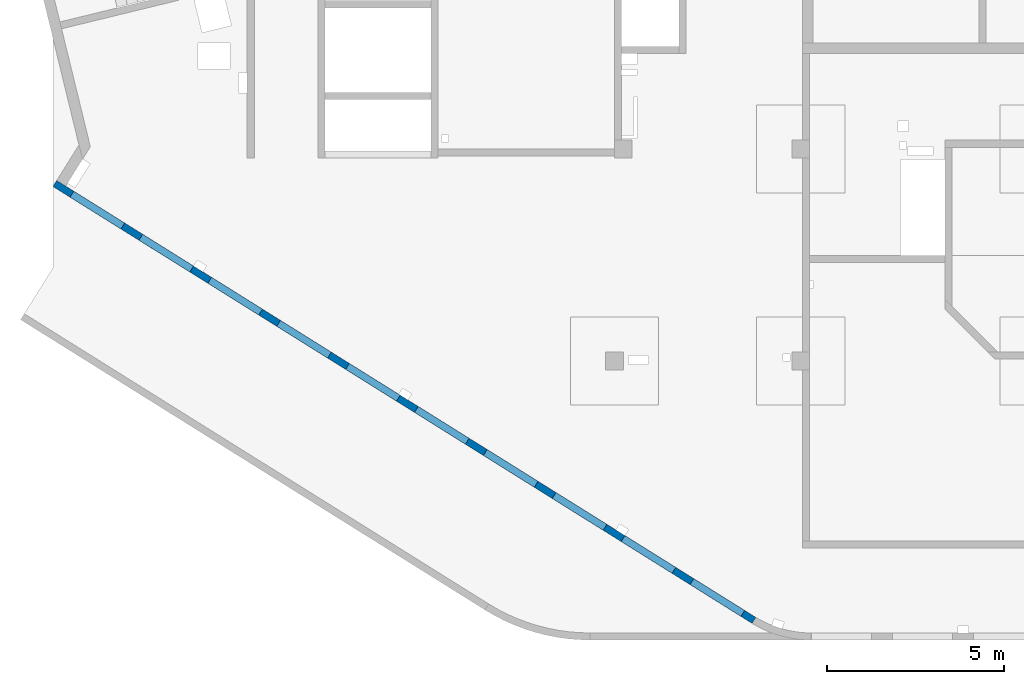
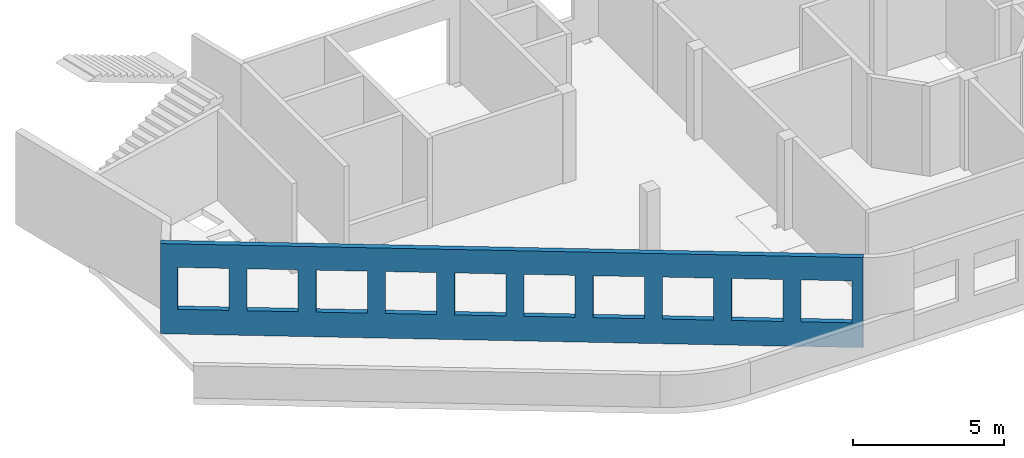
# One storey, part 7 of 10: 1 wall, 10 openings.
"""IFC4 building model written with IfcOpenShell, lengths in millimetres."""

from ifc_helpers import new_model, entity, si_unit, converted_unit, derived_unit, direction, frame, origin, place, context, subcontext, project, spatial, indexed_curve, outline, extrude, polygons, material, type_object, element, save


model = new_model("IFC4")

# Units and contexts
model_context = context("Model", 3, precision=0.01, world=origin(), true_north=direction((6.12303176911189e-17, 1.0)))
plan_context = context("Plan", 3, precision=0.01, world=origin(), true_north=direction((6.12303176911189e-17, 1.0)))
body_context = subcontext(model_context, "Body", "Model", "MODEL_VIEW")
ifc_project = project(units=[si_unit("LENGTHUNIT", "METRE", prefix="MILLI"), si_unit("AREAUNIT", "SQUARE_METRE"), si_unit("VOLUMEUNIT", "CUBIC_METRE"), converted_unit("PLANEANGLEUNIT", "DEGREE", entity("IfcRatioMeasure", 0.0174532925199433), si_unit("PLANEANGLEUNIT", "RADIAN"), dimensions=[0, 0, 0, 0, 0, 0, 0]), si_unit("MASSUNIT", "GRAM", prefix="KILO"), derived_unit("MASSDENSITYUNIT", [(si_unit("MASSUNIT", "GRAM", prefix="KILO"), 1), (si_unit("LENGTHUNIT", "METRE"), -3)]), derived_unit("MOMENTOFINERTIAUNIT", [(si_unit("LENGTHUNIT", "METRE"), 4)]), si_unit("TIMEUNIT", "SECOND"), si_unit("FREQUENCYUNIT", "HERTZ"), si_unit("THERMODYNAMICTEMPERATUREUNIT", "DEGREE_CELSIUS"), derived_unit("THERMALTRANSMITTANCEUNIT", [(si_unit("MASSUNIT", "GRAM", prefix="KILO"), 1), (si_unit("THERMODYNAMICTEMPERATUREUNIT", "KELVIN"), -1), (si_unit("TIMEUNIT", "SECOND"), -3)]), derived_unit("VOLUMETRICFLOWRATEUNIT", [(si_unit("LENGTHUNIT", "METRE"), 3), (si_unit("TIMEUNIT", "SECOND"), -1)]), derived_unit("MASSFLOWRATEUNIT", [(si_unit("MASSUNIT", "GRAM", prefix="KILO"), 1), (si_unit("TIMEUNIT", "SECOND"), -1)]), derived_unit("ROTATIONALFREQUENCYUNIT", [(si_unit("TIMEUNIT", "SECOND"), -1)]), si_unit("ELECTRICCURRENTUNIT", "AMPERE"), si_unit("ELECTRICVOLTAGEUNIT", "VOLT"), si_unit("POWERUNIT", "WATT"), si_unit("FORCEUNIT", "NEWTON", prefix="KILO"), si_unit("ILLUMINANCEUNIT", "LUX"), si_unit("LUMINOUSFLUXUNIT", "LUMEN"), si_unit("LUMINOUSINTENSITYUNIT", "CANDELA"), derived_unit("USERDEFINED", [(si_unit("MASSUNIT", "GRAM", prefix="KILO"), -1), (si_unit("LENGTHUNIT", "METRE"), -2), (si_unit("TIMEUNIT", "SECOND"), 3), (si_unit("LUMINOUSFLUXUNIT", "LUMEN"), 1)]), derived_unit("LINEARVELOCITYUNIT", [(si_unit("LENGTHUNIT", "METRE"), 1), (si_unit("TIMEUNIT", "SECOND"), -1)]), si_unit("PRESSUREUNIT", "PASCAL"), derived_unit("USERDEFINED", [(si_unit("LENGTHUNIT", "METRE"), -2), (si_unit("MASSUNIT", "GRAM", prefix="KILO"), 1), (si_unit("TIMEUNIT", "SECOND"), -2)]), derived_unit("LINEARFORCEUNIT", [(si_unit("MASSUNIT", "GRAM", prefix="KILO"), 1), (si_unit("LENGTHUNIT", "METRE"), 1), (si_unit("TIMEUNIT", "SECOND"), -2), (si_unit("LENGTHUNIT", "METRE"), -1)]), derived_unit("PLANARFORCEUNIT", [(si_unit("MASSUNIT", "GRAM", prefix="KILO"), 1), (si_unit("LENGTHUNIT", "METRE"), 1), (si_unit("TIMEUNIT", "SECOND"), -2), (si_unit("LENGTHUNIT", "METRE"), -2)])], contexts=[model_context, plan_context])

# Site, building, storey
site_placement = place(None, origin())
site = spatial("IfcSite", under=ifc_project, at=site_placement, CompositionType="ELEMENT")
building_placement = place(site_placement, origin())
building = spatial("IfcBuilding", under=site, at=building_placement, CompositionType="ELEMENT")
storey_placement = place(building_placement, frame((0.0, 0.0, 4200.0)))
storey = spatial("IfcBuildingStorey", under=building, at=storey_placement, Name="02", CompositionType="ELEMENT", Elevation=4200.0)

# Wall, openings
ifc_material = material()
wall_type = type_object("IfcWallType", Name=":ADSK_ 25_200", PredefinedType="STANDARD")
wall_placement = place(storey_placement, frame((19848.26, 354.97, -150.0), z_axis=(0.0, 0.0, 1.0), x_axis=(-0.848052743777572, 0.529911826412028, 0.0)))
wall = element("IfcWall", 1, at=wall_placement, inside=storey, type_object=wall_type, material=ifc_material, Name=":ADSK_ 25_200", ObjectType=":ADSK_ 25_200", PredefinedType="NOTDEFINED", context=body_context, shape_type="Tessellation", body=[
    polygons([(372.190668142856, -100.000000000002, 2700.0), (2072.19066814286, -99.9999999999992, 2700.0), (2072.19066814286, -99.9999999999992, 1000.00000000001), (372.190668142856, -100.000000000002, 1000.00000000001), (2672.19066814286, -99.9999999999992, 2700.0), (4372.19066814286, -99.9999999999973, 2700.0), (4372.19066814286, -99.9999999999973, 1000.00000000001), (2672.19066814286, -99.9999999999992, 1000.00000000001), (4972.19066814287, -99.9999999999968, 2700.0), (6672.19066814287, -99.9999999999946, 2700.0), (6672.19066814287, -99.9999999999946, 1000.00000000001), (4972.19066814287, -99.9999999999968, 1000.00000000001), (7272.19066814288, -99.9999999999935, 2700.0), (8972.19066814288, -99.9999999999924, 2700.0), (8972.19066814288, -99.9999999999924, 1000.00000000001), (7272.19066814288, -99.9999999999935, 1000.00000000001), (9572.19066814288, -99.9999999999913, 2700.0), (11272.1906681429, -99.9999999999913, 2700.0), (11272.1906681429, -99.9999999999913, 1000.00000000001), (9572.19066814288, -99.9999999999913, 1000.00000000001), (11872.1906681429, -99.9999999999892, 2700.0), (13572.1906681429, -99.9999999999881, 2700.0), (13572.1906681429, -99.9999999999881, 1000.00000000001), (11872.1906681429, -99.9999999999892, 1000.00000000001), (14172.1906681429, -99.9999999999859, 2700.0), (15872.1906681429, -99.9999999999859, 2700.0), (15872.1906681429, -99.9999999999859, 1000.00000000001), (14172.1906681429, -99.9999999999859, 1000.00000000001), (16472.1906681429, -99.9999999999849, 2700.0), (18172.1906681429, -99.9999999999827, 2700.0), (18172.1906681429, -99.9999999999827, 1000.00000000001), (16472.1906681429, -99.9999999999849, 1000.00000000001), (18772.1906681429, -99.9999999999827, 2700.0), (20472.1906681429, -99.9999999999794, 2700.0), (20472.1906681429, -99.9999999999794, 1000.00000000001), (18772.1906681429, -99.9999999999827, 1000.00000000001), (21072.1906681429, -99.9999999999794, 2700.0), (22772.1906681429, -99.9999999999773, 2700.0), (22772.1906681429, -99.9999999999773, 1000.00000000001), (21072.1906681429, -99.9999999999794, 1000.00000000001), (0.970164127873786, -99.9999999999997, 5.41433564649196e-13), (23041.7760623233, -99.9999999999989, 5.41433564649196e-13), (23341.7760623233, -100.000000000001, 5.41433564649196e-13), (23341.7760623233, -99.9999999999989, 3650.0), (23041.7760623233, -99.9999999999989, 3650.0), (18772.1906681429, -100.0, 3650.0), (18472.188348855, -99.9999999999978, 3650.0), (14002.1883486828, -100.0, 3650.0), (13802.1857175861, -99.9999999999989, 3650.0), (4972.1865942764, -99.9999999999995, 3650.0), (4672.18834832425, -99.9999999999995, 3650.0), (297.188348155941, -99.9999999999986, 3650.0), (97.1857170592183, -99.9999999999997, 3650.0), (0.97016412787338, -99.999999999999, 3650.0), (3.14708259452345e-12, 100.000000000001, 5.41433564649196e-13), (-6.42952358020921e-13, 99.9999999999993, 3650.0), (23341.7760623233, 99.9999999999989, 3650.0), (23341.7760623233, 99.9999999999989, 5.41433564649196e-13), (2072.19066814285, 100.000000000319, 2700.0), (372.190668142856, 100.000000000318, 2700.0), (372.190668142856, 100.000000000318, 1000.00000000001), (2072.19066814285, 100.00000000032, 1000.00000000001), (4372.19066814286, 100.000000000324, 2700.0), (2672.19066814286, 100.00000000032, 2700.0), (2672.19066814286, 100.00000000032, 1000.00000000001), (4372.19066814286, 100.000000000324, 1000.00000000001), (6672.19066814287, 100.000000000325, 2700.0), (4972.19066814287, 100.000000000323, 2700.0), (4972.19066814287, 100.000000000323, 1000.00000000001), (6672.19066814287, 100.000000000325, 1000.00000000001), (8972.19066814287, 100.000000000329, 2700.0), (7272.19066814287, 100.000000000325, 2700.0), (7272.19066814287, 100.000000000325, 1000.00000000001), (8972.19066814287, 100.000000000329, 1000.00000000001), (11272.1906681429, 100.000000000329, 2700.0), (9572.19066814288, 100.000000000327, 2700.0), (9572.19066814288, 100.000000000327, 1000.00000000001), (11272.1906681429, 100.000000000329, 1000.00000000001), (13572.1906681429, 100.000000000332, 2700.0), (11872.1906681429, 100.000000000331, 2700.0), (11872.1906681429, 100.000000000331, 1000.00000000001), (13572.1906681429, 100.000000000332, 1000.00000000001), (15872.1906681429, 100.000000000336, 2700.0), (14172.1906681429, 100.000000000334, 2700.0), (14172.1906681429, 100.000000000334, 1000.00000000001), (15872.1906681429, 100.000000000336, 1000.00000000001), (18172.1906681429, 100.000000000337, 2700.0), (16472.1906681429, 100.000000000336, 2700.0), (16472.1906681429, 100.000000000336, 1000.00000000001), (18172.1906681429, 100.000000000337, 1000.00000000001), (20472.1906681429, 100.000000000339, 2700.0), (18772.1906681429, 100.000000000337, 2700.0), (18772.1906681429, 100.000000000338, 1000.00000000001), (20472.1906681429, 100.000000000338, 1000.00000000001), (22772.1906681429, 100.000000000343, 2700.0), (21072.1906681429, 100.00000000034, 2700.0), (21072.1906681429, 100.00000000034, 1000.00000000001), (22772.1906681429, 100.000000000343, 1000.00000000001)], [[[41, 42, 43, 44, 45, 46, 47, 48, 49, 50, 51, 52, 53, 54], [1, 2, 3, 4], [5, 6, 7, 8], [9, 10, 11, 12], [13, 14, 15, 16], [17, 18, 19, 20], [21, 22, 23, 24], [25, 26, 27, 28], [29, 30, 31, 32], [33, 34, 35, 36], [37, 38, 39, 40]], [[55, 56, 57, 58], [59, 60, 61, 62], [63, 64, 65, 66], [67, 68, 69, 70], [71, 72, 73, 74], [75, 76, 77, 78], [79, 80, 81, 82], [83, 84, 85, 86], [87, 88, 89, 90], [91, 92, 93, 94], [95, 96, 97, 98]], [[43, 42, 41, 55, 58]], [[54, 53, 52, 51, 50, 49, 48, 47, 46, 45, 44, 57, 56]], [[41, 54, 56, 55]], [[44, 43, 58, 57]], [[60, 59, 2, 1]], [[60, 1, 4, 61]], [[61, 4, 3, 62]], [[2, 59, 62, 3]], [[64, 63, 6, 5]], [[64, 5, 8, 65]], [[65, 8, 7, 66]], [[6, 63, 66, 7]], [[68, 67, 10, 9]], [[68, 9, 12, 69]], [[69, 12, 11, 70]], [[10, 67, 70, 11]], [[72, 71, 14, 13]], [[72, 13, 16, 73]], [[73, 16, 15, 74]], [[14, 71, 74, 15]], [[76, 75, 18, 17]], [[76, 17, 20, 77]], [[77, 20, 19, 78]], [[18, 75, 78, 19]], [[80, 79, 22, 21]], [[80, 21, 24, 81]], [[81, 24, 23, 82]], [[22, 79, 82, 23]], [[84, 83, 26, 25]], [[84, 25, 28, 85]], [[85, 28, 27, 86]], [[26, 83, 86, 27]], [[88, 87, 30, 29]], [[88, 29, 32, 89]], [[89, 32, 31, 90]], [[30, 87, 90, 31]], [[92, 91, 34, 33]], [[92, 33, 36, 93]], [[93, 36, 35, 94]], [[34, 91, 94, 35]], [[96, 95, 38, 37]], [[96, 37, 40, 97]], [[97, 40, 39, 98]], [[38, 95, 98, 39]]], closed=True),
])
placement = place(wall_placement, frame((16644.27, 10818.86, 150.0), z_axis=(0.0, 0.0, 1.0), x_axis=(-0.848052743777572, -0.529911826412028, 0.0)))
element("IfcOpeningElement", 2, at=placement, cuts=wall, Name=":ADSK_ 25_200", PredefinedType="OPENING", context=body_context, shape_type="SweptSolid", body=[
    extrude(outline(indexed_curve([(-849.999999999994, -849.999999999999), (849.999999999993, -849.999999999999), (849.999999999993, 850.0), (-849.999999999994, 850.0), (-849.999999999994, -849.999999999999)], self_intersect=False)), frame((9112.16, 7181.41, 1700.0), z_axis=(-0.529911826412026, -0.848052743777574, 0.0), x_axis=(0.0, 0.0, -1.0)), (0.0, 0.0, 1.0), 200.000000000964),
])
element("IfcOpeningElement", 3, at=placement, cuts=wall, Name=":ADSK_ 25_200", PredefinedType="OPENING", context=body_context, shape_type="SweptSolid", body=[
    extrude(outline(indexed_curve([(-849.999999999994, -850.0), (849.999999999993, -850.0), (849.999999999993, 850.0), (-849.999999999994, 850.0), (-849.999999999994, -850.0)], self_intersect=False)), frame((18864.77, 1087.43, 1700.0), z_axis=(-0.529911826412025, -0.848052743777574, 0.0), x_axis=(0.0, 0.0, -1.0)), (0.0, 0.0, 1.0), 200.000000000966),
])
element("IfcOpeningElement", 4, at=placement, cuts=wall, Name=":ADSK_ 25_200", PredefinedType="OPENING", context=body_context, shape_type="SweptSolid", body=[
    extrude(outline(indexed_curve([(-849.999999999994, -850.0), (849.999999999993, -850.0), (849.999999999993, 850.0), (-849.999999999994, 850.0), (-849.999999999994, -850.0)], self_intersect=False)), frame((16914.25, 2306.23, 1700.0), z_axis=(-0.529911826412025, -0.848052743777574, 0.0), x_axis=(0.0, 0.0, -1.0)), (0.0, 0.0, 1.0), 200.000000000962),
])
element("IfcOpeningElement", 5, at=placement, cuts=wall, Name=":ADSK_ 25_200", PredefinedType="OPENING", context=body_context, shape_type="SweptSolid", body=[
    extrude(outline(indexed_curve([(-849.999999999994, -850.000000000002), (849.999999999993, -850.000000000002), (849.999999999993, 849.999999999998), (-849.999999999994, 849.999999999998), (-849.999999999994, -850.000000000002)], self_intersect=False)), frame((14963.73, 3525.02, 1700.0), z_axis=(-0.529911826412025, -0.848052743777574, 0.0), x_axis=(0.0, 0.0, -1.0)), (0.0, 0.0, 1.0), 200.000000000962),
])
element("IfcOpeningElement", 6, at=placement, cuts=wall, Name=":ADSK_ 25_200", PredefinedType="OPENING", context=body_context, shape_type="SweptSolid", body=[
    extrude(outline(indexed_curve([(-849.999999999994, -850.0), (849.999999999993, -850.0), (849.999999999993, 850.0), (-849.999999999994, 850.0), (-849.999999999994, -850.0)], self_intersect=False)), frame((13013.21, 4743.82, 1700.0), z_axis=(-0.529911826412025, -0.848052743777574, 0.0), x_axis=(0.0, 0.0, -1.0)), (0.0, 0.0, 1.0), 200.000000000962),
])
element("IfcOpeningElement", 7, at=placement, cuts=wall, Name=":ADSK_ 25_200", PredefinedType="OPENING", context=body_context, shape_type="SweptSolid", body=[
    extrude(outline(indexed_curve([(-849.999999999994, -850.0), (849.999999999993, -850.0), (849.999999999993, 850.0), (-849.999999999994, 850.0), (-849.999999999994, -850.0)], self_intersect=False)), frame((1310.08, 12056.6, 1700.0), z_axis=(-0.529911826412026, -0.848052743777574, 0.0), x_axis=(0.0, 0.0, -1.0)), (0.0, 0.0, 1.0), 200.000000000959),
])
element("IfcOpeningElement", 8, at=placement, cuts=wall, Name=":ADSK_ 25_200", PredefinedType="OPENING", context=body_context, shape_type="SweptSolid", body=[
    extrude(outline(indexed_curve([(-849.999999999994, -850.0), (849.999999999993, -850.0), (849.999999999993, 850.0), (-849.999999999994, 850.0), (-849.999999999994, -850.0)], self_intersect=False)), frame((3260.6, 10837.81, 1700.0), z_axis=(-0.529911826412026, -0.848052743777574, 0.0), x_axis=(0.0, 0.0, -1.0)), (0.0, 0.0, 1.0), 200.000000000962),
])
element("IfcOpeningElement", 9, at=placement, cuts=wall, Name=":ADSK_ 25_200", PredefinedType="OPENING", context=body_context, shape_type="SweptSolid", body=[
    extrude(outline(indexed_curve([(-849.999999999994, -850.0), (849.999999999993, -850.0), (849.999999999993, 850.0), (-849.999999999994, 850.0), (-849.999999999994, -850.0)], self_intersect=False)), frame((5211.12, 9619.01, 1700.0), z_axis=(-0.529911826412025, -0.848052743777574, 0.0), x_axis=(0.0, 0.0, -1.0)), (0.0, 0.0, 1.0), 200.000000000962),
])
element("IfcOpeningElement", 10, at=placement, cuts=wall, Name=":ADSK_ 25_200", PredefinedType="OPENING", context=body_context, shape_type="SweptSolid", body=[
    extrude(outline(indexed_curve([(-849.999999999994, -850.0), (849.999999999993, -850.0), (849.999999999993, 850.0), (-849.999999999994, 850.0), (-849.999999999994, -850.0)], self_intersect=False)), frame((11062.68, 5962.62, 1700.0), z_axis=(-0.529911826412025, -0.848052743777574, 0.0), x_axis=(0.0, 0.0, -1.0)), (0.0, 0.0, 1.0), 200.000000000964),
])
element("IfcOpeningElement", 11, at=placement, cuts=wall, Name=":ADSK_ 25_200", PredefinedType="OPENING", context=body_context, shape_type="SweptSolid", body=[
    extrude(outline(indexed_curve([(-849.999999999994, -849.999999999999), (849.999999999993, -849.999999999999), (849.999999999993, 850.0), (-849.999999999994, 850.0), (-849.999999999994, -849.999999999999)], self_intersect=False)), frame((7161.64, 8400.21, 1700.0), z_axis=(-0.529911826412026, -0.848052743777574, 0.0), x_axis=(0.0, 0.0, -1.0)), (0.0, 0.0, 1.0), 200.000000000964),
])

save(model, "model.ifc")
